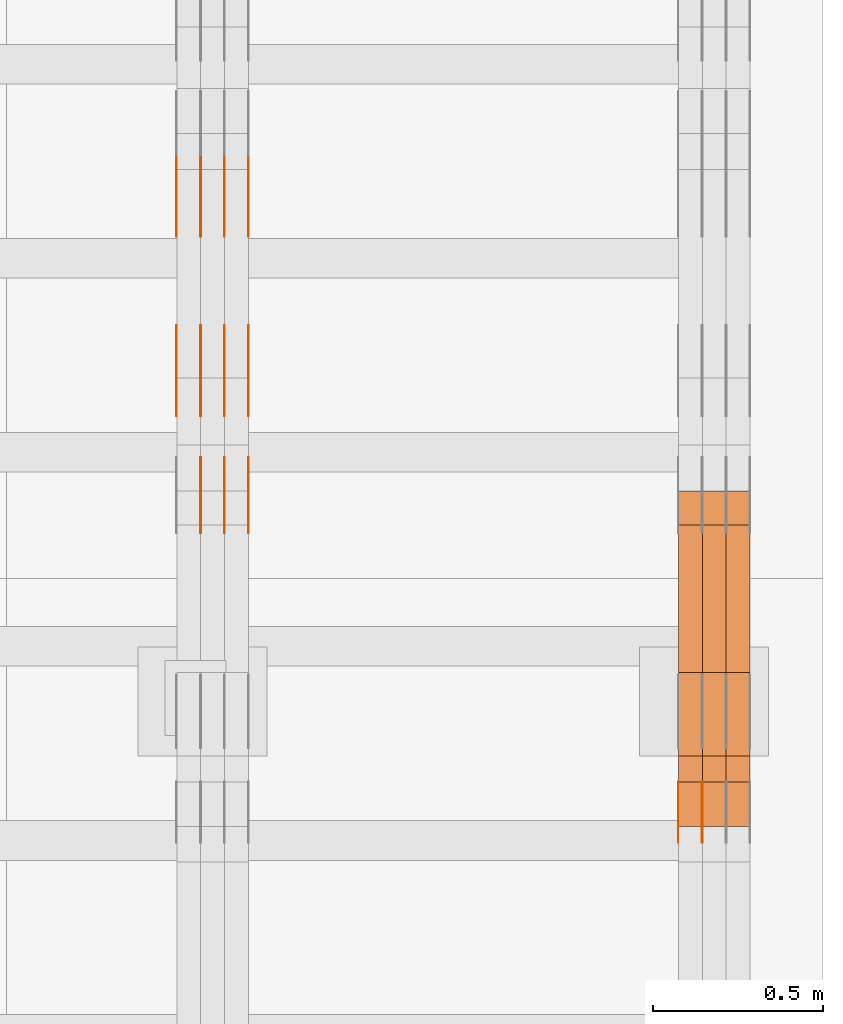
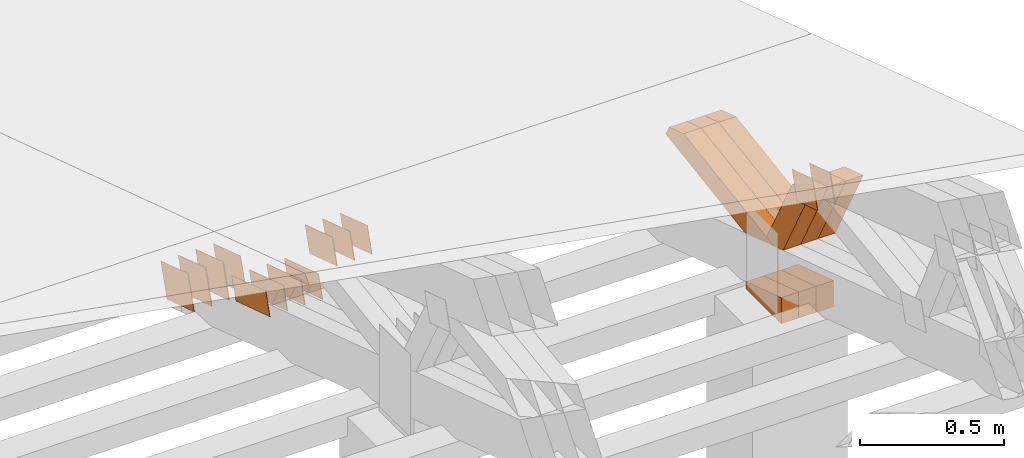
# One storey, part 328 of 385: 29 proxies.
"""IFC2X3 building model written with IfcOpenShell, lengths in millimetres."""

from ifc_helpers import new_model, entity, si_unit, converted_unit, derived_unit, direction, frame, origin, place, context, subcontext, project, spatial, polyline, outline, extrude, source, transform, mapped, material, type_object, type_shapes, element, save


model = new_model("IFC2X3")

# Units and contexts
model_context = context("Model", 3, precision=0.01, world=origin(), true_north=direction((6.12303176911189e-17, 1.0)))
body_context = subcontext(model_context, "Body", "Model", "MODEL_VIEW")
ifc_project = project(units=[si_unit("LENGTHUNIT", "METRE", prefix="MILLI"), si_unit("AREAUNIT", "SQUARE_METRE"), si_unit("VOLUMEUNIT", "CUBIC_METRE"), converted_unit("PLANEANGLEUNIT", "DEGREE", entity("IfcRatioMeasure", 0.0174532925199433), si_unit("PLANEANGLEUNIT", "RADIAN"), dimensions=[0, 0, 0, 0, 0, 0, 0]), si_unit("MASSUNIT", "GRAM", prefix="KILO"), derived_unit("MASSDENSITYUNIT", [(si_unit("MASSUNIT", "GRAM", prefix="KILO"), 1), (si_unit("LENGTHUNIT", "METRE"), -3)]), si_unit("TIMEUNIT", "SECOND"), si_unit("FREQUENCYUNIT", "HERTZ"), si_unit("THERMODYNAMICTEMPERATUREUNIT", "DEGREE_CELSIUS"), derived_unit("THERMALTRANSMITTANCEUNIT", [(si_unit("MASSUNIT", "GRAM", prefix="KILO"), 1), (si_unit("THERMODYNAMICTEMPERATUREUNIT", "KELVIN"), -1), (si_unit("TIMEUNIT", "SECOND"), -3)]), derived_unit("VOLUMETRICFLOWRATEUNIT", [(si_unit("LENGTHUNIT", "METRE"), 3), (si_unit("TIMEUNIT", "SECOND"), -1)]), si_unit("ELECTRICCURRENTUNIT", "AMPERE"), si_unit("ELECTRICVOLTAGEUNIT", "VOLT"), si_unit("POWERUNIT", "WATT"), si_unit("FORCEUNIT", "NEWTON", prefix="KILO"), si_unit("ILLUMINANCEUNIT", "LUX"), si_unit("LUMINOUSFLUXUNIT", "LUMEN"), si_unit("LUMINOUSINTENSITYUNIT", "CANDELA"), derived_unit("USERDEFINED", [(si_unit("MASSUNIT", "GRAM", prefix="KILO"), -1), (si_unit("LENGTHUNIT", "METRE"), -2), (si_unit("TIMEUNIT", "SECOND"), 3), (si_unit("LUMINOUSFLUXUNIT", "LUMEN"), 1)]), derived_unit("LINEARVELOCITYUNIT", [(si_unit("LENGTHUNIT", "METRE"), 1), (si_unit("TIMEUNIT", "SECOND"), -1)]), si_unit("PRESSUREUNIT", "PASCAL"), derived_unit("USERDEFINED", [(si_unit("LENGTHUNIT", "METRE"), -2), (si_unit("MASSUNIT", "GRAM", prefix="KILO"), 1), (si_unit("TIMEUNIT", "SECOND"), -2)])], contexts=[model_context])

# Site, building, storey
site_placement = place(None, origin())
site = spatial("IfcSite", under=ifc_project, at=site_placement, CompositionType="ELEMENT")
building_placement = place(site_placement, origin())
building = spatial("IfcBuilding", under=site, at=building_placement, CompositionType="ELEMENT")
storey_placement = place(building_placement, origin())
storey = spatial("IfcBuildingStorey", under=building, at=storey_placement, Name="Default", CompositionType="ELEMENT", Elevation=0.0)

# Proxies
ifc_material_1 = material(Name="IfcSurfaceStyle #612235")
building_element_proxy_type_1 = type_object("IfcBuildingElementProxyType", PredefinedType="NOTDEFINED", material=ifc_material_1)
shared_shape_1 = source(origin(), body_context, "Body", "SweptSolid", [
    extrude(outline(polyline([(-74.9998605591058, -59.9999264677524), (74.999875428623, -59.9999264677524), (74.9998605591068, 59.9999264677524), (-74.9998754286239, 59.9999264677524), (-74.9998605591058, -59.9999264677524)])), frame((75.0002460484325, 60.0000016373508, 0.0), z_axis=(0.0, 0.0, 1.0), x_axis=(-1.0, 0.0, 0.0)), (0.0, 0.0, 1.0), 1.29999999999999),
])
type_shapes(building_element_proxy_type_1, [shared_shape_1])
proxy_1_placement = place(building_placement, frame((49720.0, 17107.0599369346, 3383.82825001787), z_axis=(-1.0, 0.0, 0.0), x_axis=(0.0, -0.951056516295154, 0.309016994374948)))
element("IfcBuildingElementProxy", 1, at=proxy_1_placement, inside=storey, type_object=building_element_proxy_type_1, material=ifc_material_1, context=body_context, shape_type="MappedRepresentation", body=[
    mapped(shared_shape_1, transform((0.0, 0.0, 0.0), scale=1.0)),
])
ifc_material_2 = material(Name="IfcSurfaceStyle #612178")
building_element_proxy_type_2 = type_object("IfcBuildingElementProxyType", PredefinedType="NOTDEFINED", material=ifc_material_2)
shared_shape_2 = source(origin(), body_context, "Body", "SweptSolid", [
    extrude(outline(polyline([(-74.9998605591058, -59.9999264677524), (74.999875428623, -59.9999264677524), (74.9998605591068, 59.9999264677524), (-74.9998754286239, 59.9999264677524), (-74.9998605591058, -59.9999264677524)])), frame((75.0002460484325, 60.0000016373508, 0.0), z_axis=(0.0, 0.0, 1.0), x_axis=(-1.0, 0.0, 0.0)), (0.0, 0.0, 1.0), 1.29999999999999),
])
type_shapes(building_element_proxy_type_2, [shared_shape_2])
proxy_2_placement = place(building_placement, frame((49721.3, 17107.0599369346, 3383.82825001787), z_axis=(-1.0, 0.0, 0.0), x_axis=(0.0, -0.951056516295154, 0.309016994374948)))
element("IfcBuildingElementProxy", 2, at=proxy_2_placement, inside=storey, type_object=building_element_proxy_type_2, material=ifc_material_2, context=body_context, shape_type="MappedRepresentation", body=[
    mapped(shared_shape_2, transform((0.0, 0.0, 0.0), scale=1.0)),
])
ifc_material_3 = material(Name="IfcSurfaceStyle #612121")
building_element_proxy_type_3 = type_object("IfcBuildingElementProxyType", PredefinedType="NOTDEFINED", material=ifc_material_3)
shared_shape_3 = source(origin(), body_context, "Body", "SweptSolid", [
    extrude(outline(polyline([(-74.9998605591058, -59.9999264677524), (74.999875428623, -59.9999264677524), (74.9998605591068, 59.9999264677524), (-74.9998754286239, 59.9999264677524), (-74.9998605591058, -59.9999264677524)])), frame((75.0002460484325, 60.0000016373508, 0.0), z_axis=(0.0, 0.0, 1.0), x_axis=(-1.0, 0.0, 0.0)), (0.0, 0.0, 1.0), 1.29999999999999),
])
type_shapes(building_element_proxy_type_3, [shared_shape_3])
proxy_3_placement = place(building_placement, frame((49650.0, 17107.0599369346, 3383.82825001787), z_axis=(-1.0, 0.0, 0.0), x_axis=(0.0, -0.951056516295154, 0.309016994374948)))
element("IfcBuildingElementProxy", 3, at=proxy_3_placement, inside=storey, type_object=building_element_proxy_type_3, material=ifc_material_3, context=body_context, shape_type="MappedRepresentation", body=[
    mapped(shared_shape_3, transform((0.0, 0.0, 0.0), scale=1.0)),
])
ifc_material_4 = material(Name="IfcSurfaceStyle #604117")
building_element_proxy_type_4 = type_object("IfcBuildingElementProxyType", Name="T2-E1 604115", PredefinedType="NOTDEFINED", material=ifc_material_4)
shared_shape_4 = source(origin(), body_context, "Body", "SweptSolid", [
    extrude(outline(polyline([(4.4675903320374, -122.500000000001), (35.3350219726624, -122.500000000001), (35.3350219726501, 122.500000000001), (-75.1376342773499, 122.500000000001), (4.4675903320374, -122.500000000001)])), frame((35.3350219726624, 122.50000005215, 0.0), z_axis=(0.0, 0.0, 1.0), x_axis=(-1.0, 0.0, 0.0)), (0.0, 0.0, 1.0), 70.0),
])
type_shapes(building_element_proxy_type_4, [shared_shape_4])
proxy_4_placement = place(building_placement, frame((49860.0, 17220.0, 2794.30932617186), z_axis=(-1.0, 0.0, 0.0), x_axis=(0.0, 0.0, 1.0)))
element("IfcBuildingElementProxy", 4, at=proxy_4_placement, inside=storey, type_object=building_element_proxy_type_4, material=ifc_material_4, Name="T2-E1", context=body_context, shape_type="MappedRepresentation", body=[
    mapped(shared_shape_4, transform((0.0, 0.0, 0.0), scale=1.0)),
])
ifc_material_5 = material(Name="IfcSurfaceStyle #604060")
building_element_proxy_type_5 = type_object("IfcBuildingElementProxyType", Name="T2-E1 604058", PredefinedType="NOTDEFINED", material=ifc_material_5)
shared_shape_5 = source(origin(), body_context, "Body", "SweptSolid", [
    extrude(outline(polyline([(4.4675903320374, -122.500000000001), (35.3350219726624, -122.500000000001), (35.3350219726501, 122.500000000001), (-75.1376342773499, 122.500000000001), (4.4675903320374, -122.500000000001)])), frame((35.3350219726624, 122.50000005215, 0.0), z_axis=(0.0, 0.0, 1.0), x_axis=(-1.0, 0.0, 0.0)), (0.0, 0.0, 1.0), 70.0),
])
type_shapes(building_element_proxy_type_5, [shared_shape_5])
proxy_5_placement = place(building_placement, frame((49790.0, 17220.0, 2794.30932617186), z_axis=(-1.0, 0.0, 0.0), x_axis=(0.0, 0.0, 1.0)))
element("IfcBuildingElementProxy", 5, at=proxy_5_placement, inside=storey, type_object=building_element_proxy_type_5, material=ifc_material_5, Name="T2-E1", context=body_context, shape_type="MappedRepresentation", body=[
    mapped(shared_shape_5, transform((0.0, 0.0, 0.0), scale=1.0)),
])
ifc_material_6 = material(Name="IfcSurfaceStyle #604003")
building_element_proxy_type_6 = type_object("IfcBuildingElementProxyType", Name="T2-E1 604001", PredefinedType="NOTDEFINED", material=ifc_material_6)
shared_shape_6 = source(origin(), body_context, "Body", "SweptSolid", [
    extrude(outline(polyline([(4.4675903320374, -122.500000000001), (35.3350219726624, -122.500000000001), (35.3350219726501, 122.500000000001), (-75.1376342773499, 122.500000000001), (4.4675903320374, -122.500000000001)])), frame((35.3350219726624, 122.50000005215, 0.0), z_axis=(0.0, 0.0, 1.0), x_axis=(-1.0, 0.0, 0.0)), (0.0, 0.0, 1.0), 70.0),
])
type_shapes(building_element_proxy_type_6, [shared_shape_6])
proxy_6_placement = place(building_placement, frame((49720.0, 17220.0, 2794.30932617186), z_axis=(-1.0, 0.0, 0.0), x_axis=(0.0, 0.0, 1.0)))
element("IfcBuildingElementProxy", 6, at=proxy_6_placement, inside=storey, type_object=building_element_proxy_type_6, material=ifc_material_6, Name="T2-E1", context=body_context, shape_type="MappedRepresentation", body=[
    mapped(shared_shape_6, transform((0.0, 0.0, 0.0), scale=1.0)),
])
ifc_material_7 = material(Name="IfcSurfaceStyle #602362")
building_element_proxy_type_7 = type_object("IfcBuildingElementProxyType", Name="T2-W39 602360", PredefinedType="NOTDEFINED", material=ifc_material_7)
shared_shape_7 = source(origin(), body_context, "Body", "SweptSolid", [
    extrude(outline(polyline([(-191.519946663886, -47.499928106579), (188.32936223763, -47.499928106579), (171.597440144109, 0.000249483340993841), (122.102882529753, 47.4998033649085), (-290.509738247605, 47.4998033649085), (-191.519946663886, -47.499928106579)])), frame((188.329593252001, 47.499957247623, 0.0), z_axis=(0.0, 0.0, 1.0), x_axis=(-1.0, 0.0, 0.0)), (0.0, 0.0, 1.0), 70.0),
])
type_shapes(building_element_proxy_type_7, [shared_shape_7])
proxy_7_placement = place(building_placement, frame((49860.0, 17238.5876916597, 3055.56121424762), z_axis=(-1.0, 0.0, 0.0), x_axis=(0.0, -0.472216932390777, 0.881482370080902)))
element("IfcBuildingElementProxy", 7, at=proxy_7_placement, inside=storey, type_object=building_element_proxy_type_7, material=ifc_material_7, Name="T2-W39", context=body_context, shape_type="MappedRepresentation", body=[
    mapped(shared_shape_7, transform((0.0, 0.0, 0.0), scale=1.0)),
])
ifc_material_8 = material(Name="IfcSurfaceStyle #602296")
building_element_proxy_type_8 = type_object("IfcBuildingElementProxyType", Name="T2-W39 602294", PredefinedType="NOTDEFINED", material=ifc_material_8)
shared_shape_8 = source(origin(), body_context, "Body", "SweptSolid", [
    extrude(outline(polyline([(-191.519946663886, -47.499928106579), (188.32936223763, -47.499928106579), (171.597440144109, 0.000249483340993841), (122.102882529753, 47.4998033649085), (-290.509738247605, 47.4998033649085), (-191.519946663886, -47.499928106579)])), frame((188.329593252001, 47.499957247623, 0.0), z_axis=(0.0, 0.0, 1.0), x_axis=(-1.0, 0.0, 0.0)), (0.0, 0.0, 1.0), 70.0),
])
type_shapes(building_element_proxy_type_8, [shared_shape_8])
proxy_8_placement = place(building_placement, frame((49790.0, 17238.5876916597, 3055.56121424762), z_axis=(-1.0, 0.0, 0.0), x_axis=(0.0, -0.472216932390777, 0.881482370080902)))
element("IfcBuildingElementProxy", 8, at=proxy_8_placement, inside=storey, type_object=building_element_proxy_type_8, material=ifc_material_8, Name="T2-W39", context=body_context, shape_type="MappedRepresentation", body=[
    mapped(shared_shape_8, transform((0.0, 0.0, 0.0), scale=1.0)),
])
ifc_material_9 = material(Name="IfcSurfaceStyle #602230")
building_element_proxy_type_9 = type_object("IfcBuildingElementProxyType", Name="T2-W39 602228", PredefinedType="NOTDEFINED", material=ifc_material_9)
shared_shape_9 = source(origin(), body_context, "Body", "SweptSolid", [
    extrude(outline(polyline([(-191.519946663886, -47.499928106579), (188.32936223763, -47.499928106579), (171.597440144109, 0.000249483340993841), (122.102882529753, 47.4998033649085), (-290.509738247605, 47.4998033649085), (-191.519946663886, -47.499928106579)])), frame((188.329593252001, 47.499957247623, 0.0), z_axis=(0.0, 0.0, 1.0), x_axis=(-1.0, 0.0, 0.0)), (0.0, 0.0, 1.0), 70.0),
])
type_shapes(building_element_proxy_type_9, [shared_shape_9])
proxy_9_placement = place(building_placement, frame((49720.0, 17238.5876916597, 3055.56121424762), z_axis=(-1.0, 0.0, 0.0), x_axis=(0.0, -0.472216932390777, 0.881482370080902)))
element("IfcBuildingElementProxy", 9, at=proxy_9_placement, inside=storey, type_object=building_element_proxy_type_9, material=ifc_material_9, Name="T2-W39", context=body_context, shape_type="MappedRepresentation", body=[
    mapped(shared_shape_9, transform((0.0, 0.0, 0.0), scale=1.0)),
])
ifc_material_10 = material(Name="IfcSurfaceStyle #601966")
building_element_proxy_type_10 = type_object("IfcBuildingElementProxyType", Name="T2-W10 601964", PredefinedType="NOTDEFINED", material=ifc_material_10)
shared_shape_10 = source(origin(), body_context, "Body", "SweptSolid", [
    extrude(outline(polyline([(-459.546036710757, -47.5000436364511), (174.689450869018, -47.5000436364511), (268.831081103959, 0.00011114562912502), (287.286350706789, 47.4999880636365), (-271.260845969009, 47.4999880636366), (-459.546036710757, -47.5000436364511)])), frame((287.286768781132, 47.5001637448091, 0.0), z_axis=(0.0, 0.0, 1.0), x_axis=(-1.0, 0.0, 0.0)), (0.0, 0.0, 1.0), 70.0),
])
type_shapes(building_element_proxy_type_10, [shared_shape_10])
proxy_10_placement = place(building_placement, frame((49860.0, 18025.1410649788, 3112.76453857986), z_axis=(-1.0, 0.0, 0.0), x_axis=(0.0, -0.988299196256916, -0.152527698068035)))
element("IfcBuildingElementProxy", 10, at=proxy_10_placement, inside=storey, type_object=building_element_proxy_type_10, material=ifc_material_10, Name="T2-W10", context=body_context, shape_type="MappedRepresentation", body=[
    mapped(shared_shape_10, transform((0.0, 0.0, 0.0), scale=1.0)),
])
ifc_material_11 = material(Name="IfcSurfaceStyle #601900")
building_element_proxy_type_11 = type_object("IfcBuildingElementProxyType", Name="T2-W10 601898", PredefinedType="NOTDEFINED", material=ifc_material_11)
shared_shape_11 = source(origin(), body_context, "Body", "SweptSolid", [
    extrude(outline(polyline([(-459.546036710757, -47.5000436364511), (174.689450869018, -47.5000436364511), (268.831081103959, 0.00011114562912502), (287.286350706789, 47.4999880636365), (-271.260845969009, 47.4999880636366), (-459.546036710757, -47.5000436364511)])), frame((287.286768781132, 47.5001637448091, 0.0), z_axis=(0.0, 0.0, 1.0), x_axis=(-1.0, 0.0, 0.0)), (0.0, 0.0, 1.0), 70.0),
])
type_shapes(building_element_proxy_type_11, [shared_shape_11])
proxy_11_placement = place(building_placement, frame((49790.0, 18025.1410649788, 3112.76453857986), z_axis=(-1.0, 0.0, 0.0), x_axis=(0.0, -0.988299196256916, -0.152527698068035)))
element("IfcBuildingElementProxy", 11, at=proxy_11_placement, inside=storey, type_object=building_element_proxy_type_11, material=ifc_material_11, Name="T2-W10", context=body_context, shape_type="MappedRepresentation", body=[
    mapped(shared_shape_11, transform((0.0, 0.0, 0.0), scale=1.0)),
])
ifc_material_12 = material(Name="IfcSurfaceStyle #601834")
building_element_proxy_type_12 = type_object("IfcBuildingElementProxyType", Name="T2-W10 601832", PredefinedType="NOTDEFINED", material=ifc_material_12)
shared_shape_12 = source(origin(), body_context, "Body", "SweptSolid", [
    extrude(outline(polyline([(-459.546036710757, -47.5000436364511), (174.689450869018, -47.5000436364511), (268.831081103959, 0.00011114562912502), (287.286350706789, 47.4999880636365), (-271.260845969009, 47.4999880636366), (-459.546036710757, -47.5000436364511)])), frame((287.286768781132, 47.5001637448091, 0.0), z_axis=(0.0, 0.0, 1.0), x_axis=(-1.0, 0.0, 0.0)), (0.0, 0.0, 1.0), 70.0),
])
type_shapes(building_element_proxy_type_12, [shared_shape_12])
proxy_12_placement = place(building_placement, frame((49720.0, 18025.1410649788, 3112.76453857986), z_axis=(-1.0, 0.0, 0.0), x_axis=(0.0, -0.988299196256916, -0.152527698068035)))
element("IfcBuildingElementProxy", 12, at=proxy_12_placement, inside=storey, type_object=building_element_proxy_type_12, material=ifc_material_12, Name="T2-W10", context=body_context, shape_type="MappedRepresentation", body=[
    mapped(shared_shape_12, transform((0.0, 0.0, 0.0), scale=1.0)),
])
ifc_material_13 = material(Name="IfcSurfaceStyle #583446")
building_element_proxy_type_13 = type_object("IfcBuildingElementProxyType", PredefinedType="NOTDEFINED", material=ifc_material_13)
shared_shape_13 = source(origin(), body_context, "Body", "SweptSolid", [
    extrude(outline(polyline([(-125.00031378339, -47.9999612158856), (125.000225258022, -47.9999612158856), (124.999811678525, 47.9999612158856), (-124.999723153156, 47.9999612158856), (-125.00031378339, -47.9999612158856)])), frame((125.000225258022, 48.0000091013474, 0.0), z_axis=(0.0, 0.0, 1.0), x_axis=(-1.0, 0.0, 0.0)), (0.0, 0.0, 1.0), 1.3),
])
type_shapes(building_element_proxy_type_13, [shared_shape_13])
proxy_13_placement = place(building_placement, frame((48386.3, 18456.8597683375, 2657.46691321253), z_axis=(-1.0, 0.0, 0.0), x_axis=(0.0, -0.951056516295124, 0.309016994375039)))
element("IfcBuildingElementProxy", 13, at=proxy_13_placement, inside=storey, type_object=building_element_proxy_type_13, material=ifc_material_13, context=body_context, shape_type="MappedRepresentation", body=[
    mapped(shared_shape_13, transform((0.0, 0.0, 0.0), scale=1.0)),
])
ifc_material_14 = material(Name="IfcSurfaceStyle #583389")
building_element_proxy_type_14 = type_object("IfcBuildingElementProxyType", PredefinedType="NOTDEFINED", material=ifc_material_14)
shared_shape_14 = source(origin(), body_context, "Body", "SweptSolid", [
    extrude(outline(polyline([(-125.00031378339, -47.9999612158856), (125.000225258022, -47.9999612158856), (124.999811678525, 47.9999612158856), (-124.999723153156, 47.9999612158856), (-125.00031378339, -47.9999612158856)])), frame((125.000225258022, 48.0000091013474, 0.0), z_axis=(0.0, 0.0, 1.0), x_axis=(-1.0, 0.0, 0.0)), (0.0, 0.0, 1.0), 1.3),
])
type_shapes(building_element_proxy_type_14, [shared_shape_14])
proxy_14_placement = place(building_placement, frame((48315.0, 18456.8597683375, 2657.46691321253), z_axis=(-1.0, 0.0, 0.0), x_axis=(0.0, -0.951056516295124, 0.309016994375039)))
element("IfcBuildingElementProxy", 14, at=proxy_14_placement, inside=storey, type_object=building_element_proxy_type_14, material=ifc_material_14, context=body_context, shape_type="MappedRepresentation", body=[
    mapped(shared_shape_14, transform((0.0, 0.0, 0.0), scale=1.0)),
])
ifc_material_15 = material(Name="IfcSurfaceStyle #583332")
building_element_proxy_type_15 = type_object("IfcBuildingElementProxyType", PredefinedType="NOTDEFINED", material=ifc_material_15)
shared_shape_15 = source(origin(), body_context, "Body", "SweptSolid", [
    extrude(outline(polyline([(-125.00031378339, -47.9999612158856), (125.000225258022, -47.9999612158856), (124.999811678525, 47.9999612158856), (-124.999723153156, 47.9999612158856), (-125.00031378339, -47.9999612158856)])), frame((125.000225258022, 48.0000091013474, 0.0), z_axis=(0.0, 0.0, 1.0), x_axis=(-1.0, 0.0, 0.0)), (0.0, 0.0, 1.0), 1.3),
])
type_shapes(building_element_proxy_type_15, [shared_shape_15])
proxy_15_placement = place(building_placement, frame((48316.3, 18456.8597683375, 2657.46691321253), z_axis=(-1.0, 0.0, 0.0), x_axis=(0.0, -0.951056516295124, 0.309016994375039)))
element("IfcBuildingElementProxy", 15, at=proxy_15_placement, inside=storey, type_object=building_element_proxy_type_15, material=ifc_material_15, context=body_context, shape_type="MappedRepresentation", body=[
    mapped(shared_shape_15, transform((0.0, 0.0, 0.0), scale=1.0)),
])
ifc_material_16 = material(Name="IfcSurfaceStyle #583275")
building_element_proxy_type_16 = type_object("IfcBuildingElementProxyType", PredefinedType="NOTDEFINED", material=ifc_material_16)
shared_shape_16 = source(origin(), body_context, "Body", "SweptSolid", [
    extrude(outline(polyline([(-125.00031378339, -47.9999612158856), (125.000225258022, -47.9999612158856), (124.999811678525, 47.9999612158856), (-124.999723153156, 47.9999612158856), (-125.00031378339, -47.9999612158856)])), frame((125.000225258022, 48.0000091013474, 0.0), z_axis=(0.0, 0.0, 1.0), x_axis=(-1.0, 0.0, 0.0)), (0.0, 0.0, 1.0), 1.29999999999998),
])
type_shapes(building_element_proxy_type_16, [shared_shape_16])
proxy_16_placement = place(building_placement, frame((48245.0, 18456.8597683375, 2657.46691321253), z_axis=(-1.0, 0.0, 0.0), x_axis=(0.0, -0.951056516295124, 0.309016994375039)))
element("IfcBuildingElementProxy", 16, at=proxy_16_placement, inside=storey, type_object=building_element_proxy_type_16, material=ifc_material_16, context=body_context, shape_type="MappedRepresentation", body=[
    mapped(shared_shape_16, transform((0.0, 0.0, 0.0), scale=1.0)),
])
ifc_material_17 = material(Name="IfcSurfaceStyle #583218")
building_element_proxy_type_17 = type_object("IfcBuildingElementProxyType", PredefinedType="NOTDEFINED", material=ifc_material_17)
shared_shape_17 = source(origin(), body_context, "Body", "SweptSolid", [
    extrude(outline(polyline([(-125.00031378339, -47.9999612158856), (125.000225258022, -47.9999612158856), (124.999811678525, 47.9999612158856), (-124.999723153156, 47.9999612158856), (-125.00031378339, -47.9999612158856)])), frame((125.000225258022, 48.0000091013474, 0.0), z_axis=(0.0, 0.0, 1.0), x_axis=(-1.0, 0.0, 0.0)), (0.0, 0.0, 1.0), 1.29999999999998),
])
type_shapes(building_element_proxy_type_17, [shared_shape_17])
proxy_17_placement = place(building_placement, frame((48246.3, 18456.8597683375, 2657.46691321253), z_axis=(-1.0, 0.0, 0.0), x_axis=(0.0, -0.951056516295124, 0.309016994375039)))
element("IfcBuildingElementProxy", 17, at=proxy_17_placement, inside=storey, type_object=building_element_proxy_type_17, material=ifc_material_17, context=body_context, shape_type="MappedRepresentation", body=[
    mapped(shared_shape_17, transform((0.0, 0.0, 0.0), scale=1.0)),
])
ifc_material_18 = material(Name="IfcSurfaceStyle #583161")
building_element_proxy_type_18 = type_object("IfcBuildingElementProxyType", PredefinedType="NOTDEFINED", material=ifc_material_18)
shared_shape_18 = source(origin(), body_context, "Body", "SweptSolid", [
    extrude(outline(polyline([(-125.00031378339, -47.9999612158856), (125.000225258022, -47.9999612158856), (124.999811678525, 47.9999612158856), (-124.999723153156, 47.9999612158856), (-125.00031378339, -47.9999612158856)])), frame((125.000225258022, 48.0000091013474, 0.0), z_axis=(0.0, 0.0, 1.0), x_axis=(-1.0, 0.0, 0.0)), (0.0, 0.0, 1.0), 1.29999999999998),
])
type_shapes(building_element_proxy_type_18, [shared_shape_18])
proxy_18_placement = place(building_placement, frame((48175.0, 18456.8597683375, 2657.46691321253), z_axis=(-1.0, 0.0, 0.0), x_axis=(0.0, -0.951056516295124, 0.309016994375039)))
element("IfcBuildingElementProxy", 18, at=proxy_18_placement, inside=storey, type_object=building_element_proxy_type_18, material=ifc_material_18, context=body_context, shape_type="MappedRepresentation", body=[
    mapped(shared_shape_18, transform((0.0, 0.0, 0.0), scale=1.0)),
])
ifc_material_19 = material(Name="IfcSurfaceStyle #581736")
building_element_proxy_type_19 = type_object("IfcBuildingElementProxyType", PredefinedType="NOTDEFINED", material=ifc_material_19)
shared_shape_19 = source(origin(), body_context, "Body", "SweptSolid", [
    extrude(outline(polyline([(-99.999796294464, -72.0000050220467), (99.9998768370438, -72.0000050220467), (100.000260677528, 72.0000050220467), (-100.000341220108, 72.0000050220467), (-99.999796294464, -72.0000050220467)])), frame((100.000260677528, 72.0000050220467, 0.0), z_axis=(0.0, 0.0, 1.0), x_axis=(-1.0, 0.0, 0.0)), (0.0, 0.0, 1.0), 1.3),
])
type_shapes(building_element_proxy_type_19, [shared_shape_19])
proxy_19_placement = place(building_placement, frame((48386.3, 18936.3876569477, 2373.90613192527), z_axis=(-1.0, 0.0, 0.0), x_axis=(0.0, -0.951056516295124, 0.309016994375039)))
element("IfcBuildingElementProxy", 19, at=proxy_19_placement, inside=storey, type_object=building_element_proxy_type_19, material=ifc_material_19, context=body_context, shape_type="MappedRepresentation", body=[
    mapped(shared_shape_19, transform((0.0, 0.0, 0.0), scale=1.0)),
])
ifc_material_20 = material(Name="IfcSurfaceStyle #581679")
building_element_proxy_type_20 = type_object("IfcBuildingElementProxyType", PredefinedType="NOTDEFINED", material=ifc_material_20)
shared_shape_20 = source(origin(), body_context, "Body", "SweptSolid", [
    extrude(outline(polyline([(-99.999796294464, -72.0000050220467), (99.9998768370438, -72.0000050220467), (100.000260677528, 72.0000050220467), (-100.000341220108, 72.0000050220467), (-99.999796294464, -72.0000050220467)])), frame((100.000260677528, 72.0000050220467, 0.0), z_axis=(0.0, 0.0, 1.0), x_axis=(-1.0, 0.0, 0.0)), (0.0, 0.0, 1.0), 1.3),
])
type_shapes(building_element_proxy_type_20, [shared_shape_20])
proxy_20_placement = place(building_placement, frame((48315.0, 18936.3876569477, 2373.90613192527), z_axis=(-1.0, 0.0, 0.0), x_axis=(0.0, -0.951056516295124, 0.309016994375039)))
element("IfcBuildingElementProxy", 20, at=proxy_20_placement, inside=storey, type_object=building_element_proxy_type_20, material=ifc_material_20, context=body_context, shape_type="MappedRepresentation", body=[
    mapped(shared_shape_20, transform((0.0, 0.0, 0.0), scale=1.0)),
])
ifc_material_21 = material(Name="IfcSurfaceStyle #581622")
building_element_proxy_type_21 = type_object("IfcBuildingElementProxyType", PredefinedType="NOTDEFINED", material=ifc_material_21)
shared_shape_21 = source(origin(), body_context, "Body", "SweptSolid", [
    extrude(outline(polyline([(-99.999796294464, -72.0000050220467), (99.9998768370438, -72.0000050220467), (100.000260677528, 72.0000050220467), (-100.000341220108, 72.0000050220467), (-99.999796294464, -72.0000050220467)])), frame((100.000260677528, 72.0000050220467, 0.0), z_axis=(0.0, 0.0, 1.0), x_axis=(-1.0, 0.0, 0.0)), (0.0, 0.0, 1.0), 1.3),
])
type_shapes(building_element_proxy_type_21, [shared_shape_21])
proxy_21_placement = place(building_placement, frame((48316.3, 18936.3876569477, 2373.90613192527), z_axis=(-1.0, 0.0, 0.0), x_axis=(0.0, -0.951056516295124, 0.309016994375039)))
element("IfcBuildingElementProxy", 21, at=proxy_21_placement, inside=storey, type_object=building_element_proxy_type_21, material=ifc_material_21, context=body_context, shape_type="MappedRepresentation", body=[
    mapped(shared_shape_21, transform((0.0, 0.0, 0.0), scale=1.0)),
])
ifc_material_22 = material(Name="IfcSurfaceStyle #581565")
building_element_proxy_type_22 = type_object("IfcBuildingElementProxyType", PredefinedType="NOTDEFINED", material=ifc_material_22)
shared_shape_22 = source(origin(), body_context, "Body", "SweptSolid", [
    extrude(outline(polyline([(-99.999796294464, -72.0000050220467), (99.9998768370438, -72.0000050220467), (100.000260677528, 72.0000050220467), (-100.000341220108, 72.0000050220467), (-99.999796294464, -72.0000050220467)])), frame((100.000260677528, 72.0000050220467, 0.0), z_axis=(0.0, 0.0, 1.0), x_axis=(-1.0, 0.0, 0.0)), (0.0, 0.0, 1.0), 1.29999999999998),
])
type_shapes(building_element_proxy_type_22, [shared_shape_22])
proxy_22_placement = place(building_placement, frame((48245.0, 18936.3876569477, 2373.90613192527), z_axis=(-1.0, 0.0, 0.0), x_axis=(0.0, -0.951056516295124, 0.309016994375039)))
element("IfcBuildingElementProxy", 22, at=proxy_22_placement, inside=storey, type_object=building_element_proxy_type_22, material=ifc_material_22, context=body_context, shape_type="MappedRepresentation", body=[
    mapped(shared_shape_22, transform((0.0, 0.0, 0.0), scale=1.0)),
])
ifc_material_23 = material(Name="IfcSurfaceStyle #581508")
building_element_proxy_type_23 = type_object("IfcBuildingElementProxyType", PredefinedType="NOTDEFINED", material=ifc_material_23)
shared_shape_23 = source(origin(), body_context, "Body", "SweptSolid", [
    extrude(outline(polyline([(-99.999796294464, -72.0000050220467), (99.9998768370438, -72.0000050220467), (100.000260677528, 72.0000050220467), (-100.000341220108, 72.0000050220467), (-99.999796294464, -72.0000050220467)])), frame((100.000260677528, 72.0000050220467, 0.0), z_axis=(0.0, 0.0, 1.0), x_axis=(-1.0, 0.0, 0.0)), (0.0, 0.0, 1.0), 1.29999999999998),
])
type_shapes(building_element_proxy_type_23, [shared_shape_23])
proxy_23_placement = place(building_placement, frame((48246.3, 18936.3876569477, 2373.90613192527), z_axis=(-1.0, 0.0, 0.0), x_axis=(0.0, -0.951056516295124, 0.309016994375039)))
element("IfcBuildingElementProxy", 23, at=proxy_23_placement, inside=storey, type_object=building_element_proxy_type_23, material=ifc_material_23, context=body_context, shape_type="MappedRepresentation", body=[
    mapped(shared_shape_23, transform((0.0, 0.0, 0.0), scale=1.0)),
])
ifc_material_24 = material(Name="IfcSurfaceStyle #581451")
building_element_proxy_type_24 = type_object("IfcBuildingElementProxyType", PredefinedType="NOTDEFINED", material=ifc_material_24)
shared_shape_24 = source(origin(), body_context, "Body", "SweptSolid", [
    extrude(outline(polyline([(-99.999796294464, -72.0000050220467), (99.9998768370438, -72.0000050220467), (100.000260677528, 72.0000050220467), (-100.000341220108, 72.0000050220467), (-99.999796294464, -72.0000050220467)])), frame((100.000260677528, 72.0000050220467, 0.0), z_axis=(0.0, 0.0, 1.0), x_axis=(-1.0, 0.0, 0.0)), (0.0, 0.0, 1.0), 1.29999999999999),
])
type_shapes(building_element_proxy_type_24, [shared_shape_24])
proxy_24_placement = place(building_placement, frame((48175.0, 18936.3876569477, 2373.90613192527), z_axis=(-1.0, 0.0, 0.0), x_axis=(0.0, -0.951056516295124, 0.309016994375039)))
element("IfcBuildingElementProxy", 24, at=proxy_24_placement, inside=storey, type_object=building_element_proxy_type_24, material=ifc_material_24, context=body_context, shape_type="MappedRepresentation", body=[
    mapped(shared_shape_24, transform((0.0, 0.0, 0.0), scale=1.0)),
])
ifc_material_25 = material(Name="IfcSurfaceStyle #577290")
building_element_proxy_type_25 = type_object("IfcBuildingElementProxyType", PredefinedType="NOTDEFINED", material=ifc_material_25)
shared_shape_25 = source(origin(), body_context, "Body", "SweptSolid", [
    extrude(outline(polyline([(-99.9999427841299, -54.0000599375792), (99.9996549037756, -54.0000599375792), (100.000407167194, 54.0000599375792), (-100.00011928684, 54.0000599375792), (-99.9999427841299, -54.0000599375792)])), frame((100.000407167194, 54.0000599375792, 0.0), z_axis=(0.0, 0.0, 1.0), x_axis=(-1.0, 0.0, 0.0)), (0.0, 0.0, 1.0), 1.3),
])
type_shapes(building_element_proxy_type_25, [shared_shape_25])
proxy_25_placement = place(building_placement, frame((48386.3, 18065.0682492591, 3072.55239547302), z_axis=(-1.0, 0.0, 0.0), x_axis=(0.0, -0.951056516295154, 0.309016994374948)))
element("IfcBuildingElementProxy", 25, at=proxy_25_placement, inside=storey, type_object=building_element_proxy_type_25, material=ifc_material_25, context=body_context, shape_type="MappedRepresentation", body=[
    mapped(shared_shape_25, transform((0.0, 0.0, 0.0), scale=1.0)),
])
ifc_material_26 = material(Name="IfcSurfaceStyle #577233")
building_element_proxy_type_26 = type_object("IfcBuildingElementProxyType", PredefinedType="NOTDEFINED", material=ifc_material_26)
shared_shape_26 = source(origin(), body_context, "Body", "SweptSolid", [
    extrude(outline(polyline([(-99.9999427841299, -54.0000599375792), (99.9996549037756, -54.0000599375792), (100.000407167194, 54.0000599375792), (-100.00011928684, 54.0000599375792), (-99.9999427841299, -54.0000599375792)])), frame((100.000407167194, 54.0000599375792, 0.0), z_axis=(0.0, 0.0, 1.0), x_axis=(-1.0, 0.0, 0.0)), (0.0, 0.0, 1.0), 1.3),
])
type_shapes(building_element_proxy_type_26, [shared_shape_26])
proxy_26_placement = place(building_placement, frame((48315.0, 18065.0682492591, 3072.55239547302), z_axis=(-1.0, 0.0, 0.0), x_axis=(0.0, -0.951056516295154, 0.309016994374948)))
element("IfcBuildingElementProxy", 26, at=proxy_26_placement, inside=storey, type_object=building_element_proxy_type_26, material=ifc_material_26, context=body_context, shape_type="MappedRepresentation", body=[
    mapped(shared_shape_26, transform((0.0, 0.0, 0.0), scale=1.0)),
])
ifc_material_27 = material(Name="IfcSurfaceStyle #577176")
building_element_proxy_type_27 = type_object("IfcBuildingElementProxyType", PredefinedType="NOTDEFINED", material=ifc_material_27)
shared_shape_27 = source(origin(), body_context, "Body", "SweptSolid", [
    extrude(outline(polyline([(-99.9999427841299, -54.0000599375792), (99.9996549037756, -54.0000599375792), (100.000407167194, 54.0000599375792), (-100.00011928684, 54.0000599375792), (-99.9999427841299, -54.0000599375792)])), frame((100.000407167194, 54.0000599375792, 0.0), z_axis=(0.0, 0.0, 1.0), x_axis=(-1.0, 0.0, 0.0)), (0.0, 0.0, 1.0), 1.3),
])
type_shapes(building_element_proxy_type_27, [shared_shape_27])
proxy_27_placement = place(building_placement, frame((48316.3, 18065.0682492591, 3072.55239547302), z_axis=(-1.0, 0.0, 0.0), x_axis=(0.0, -0.951056516295154, 0.309016994374948)))
element("IfcBuildingElementProxy", 27, at=proxy_27_placement, inside=storey, type_object=building_element_proxy_type_27, material=ifc_material_27, context=body_context, shape_type="MappedRepresentation", body=[
    mapped(shared_shape_27, transform((0.0, 0.0, 0.0), scale=1.0)),
])
ifc_material_28 = material(Name="IfcSurfaceStyle #577119")
building_element_proxy_type_28 = type_object("IfcBuildingElementProxyType", PredefinedType="NOTDEFINED", material=ifc_material_28)
shared_shape_28 = source(origin(), body_context, "Body", "SweptSolid", [
    extrude(outline(polyline([(-99.9999427841299, -54.0000599375792), (99.9996549037756, -54.0000599375792), (100.000407167194, 54.0000599375792), (-100.00011928684, 54.0000599375792), (-99.9999427841299, -54.0000599375792)])), frame((100.000407167194, 54.0000599375792, 0.0), z_axis=(0.0, 0.0, 1.0), x_axis=(-1.0, 0.0, 0.0)), (0.0, 0.0, 1.0), 1.29999999999998),
])
type_shapes(building_element_proxy_type_28, [shared_shape_28])
proxy_28_placement = place(building_placement, frame((48245.0, 18065.0682492591, 3072.55239547302), z_axis=(-1.0, 0.0, 0.0), x_axis=(0.0, -0.951056516295154, 0.309016994374948)))
element("IfcBuildingElementProxy", 28, at=proxy_28_placement, inside=storey, type_object=building_element_proxy_type_28, material=ifc_material_28, context=body_context, shape_type="MappedRepresentation", body=[
    mapped(shared_shape_28, transform((0.0, 0.0, 0.0), scale=1.0)),
])
ifc_material_29 = material(Name="IfcSurfaceStyle #577062")
building_element_proxy_type_29 = type_object("IfcBuildingElementProxyType", PredefinedType="NOTDEFINED", material=ifc_material_29)
shared_shape_29 = source(origin(), body_context, "Body", "SweptSolid", [
    extrude(outline(polyline([(-99.9999427841299, -54.0000599375792), (99.9996549037756, -54.0000599375792), (100.000407167194, 54.0000599375792), (-100.00011928684, 54.0000599375792), (-99.9999427841299, -54.0000599375792)])), frame((100.000407167194, 54.0000599375792, 0.0), z_axis=(0.0, 0.0, 1.0), x_axis=(-1.0, 0.0, 0.0)), (0.0, 0.0, 1.0), 1.29999999999998),
])
type_shapes(building_element_proxy_type_29, [shared_shape_29])
proxy_29_placement = place(building_placement, frame((48246.3, 18065.0682492591, 3072.55239547302), z_axis=(-1.0, 0.0, 0.0), x_axis=(0.0, -0.951056516295154, 0.309016994374948)))
element("IfcBuildingElementProxy", 29, at=proxy_29_placement, inside=storey, type_object=building_element_proxy_type_29, material=ifc_material_29, context=body_context, shape_type="MappedRepresentation", body=[
    mapped(shared_shape_29, transform((0.0, 0.0, 0.0), scale=1.0)),
])

save(model, "model.ifc")
